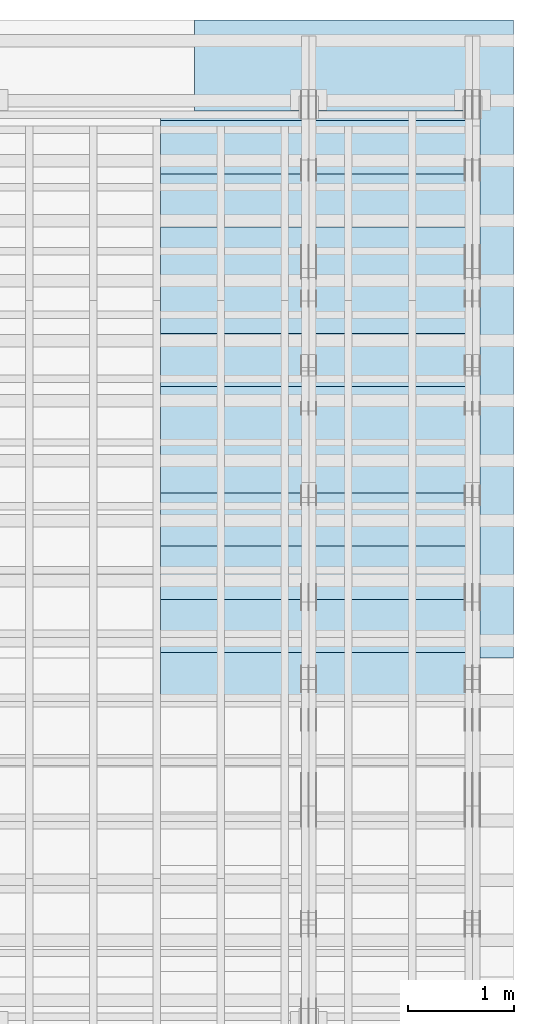
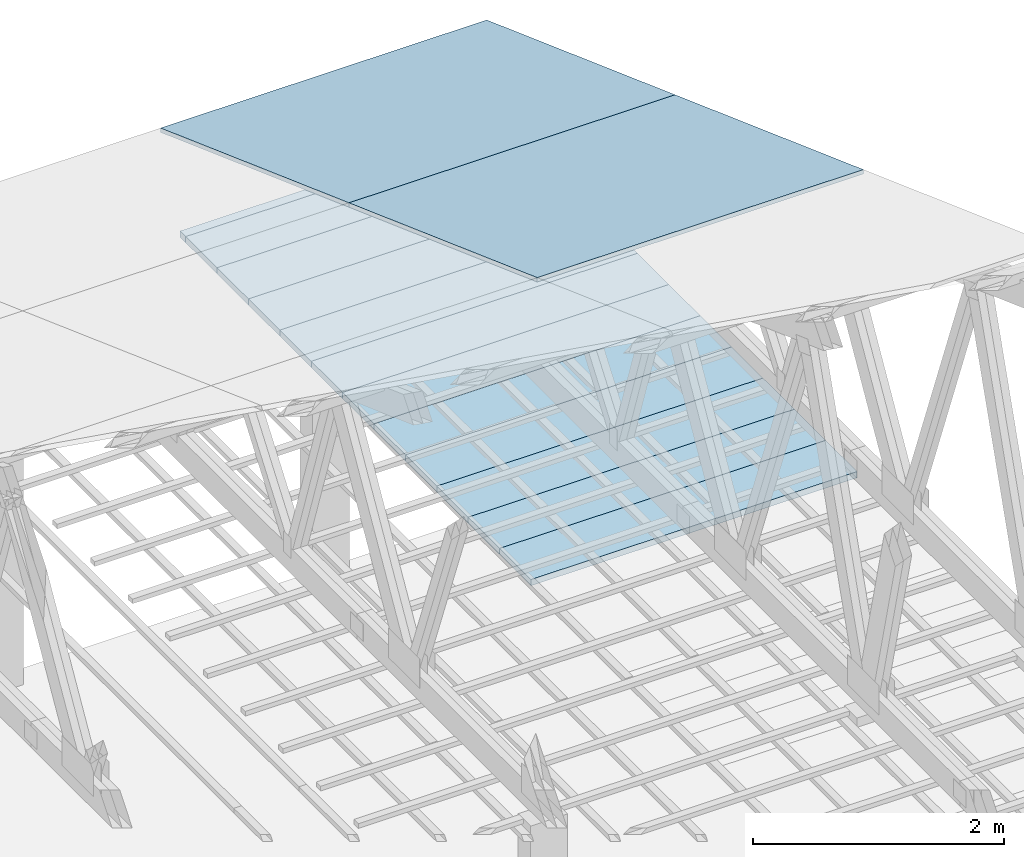
# One storey, part 11 of 189: 14 slabs, 14 elements without a shape of their own.
"""IFC2X3 building model written with IfcOpenShell, lengths in millimetres."""

from ifc_helpers import new_model, entity, si_unit, converted_unit, derived_unit, direction, frame, frame_2d, origin, origin_2d_with_axis, place, context, subcontext, project, spatial, rectangle, extrude, material, layer, layer_set, element, aggregate, save


model = new_model("IFC2X3")

# Units and contexts
model_context = context("Model", 3, precision=0.01, world=origin(), true_north=direction((6.12303176911189e-17, 1.0)))
body_context = subcontext(model_context, "Body", "Model", "MODEL_VIEW")
ifc_project = project(units=[si_unit("LENGTHUNIT", "METRE", prefix="MILLI"), si_unit("AREAUNIT", "SQUARE_METRE"), si_unit("VOLUMEUNIT", "CUBIC_METRE"), converted_unit("PLANEANGLEUNIT", "DEGREE", entity("IfcRatioMeasure", 0.0174532925199433), si_unit("PLANEANGLEUNIT", "RADIAN"), dimensions=[0, 0, 0, 0, 0, 0, 0]), si_unit("MASSUNIT", "GRAM", prefix="KILO"), derived_unit("MASSDENSITYUNIT", [(si_unit("MASSUNIT", "GRAM", prefix="KILO"), 1), (si_unit("LENGTHUNIT", "METRE"), -3)]), si_unit("TIMEUNIT", "SECOND"), si_unit("FREQUENCYUNIT", "HERTZ"), si_unit("THERMODYNAMICTEMPERATUREUNIT", "DEGREE_CELSIUS"), derived_unit("THERMALTRANSMITTANCEUNIT", [(si_unit("MASSUNIT", "GRAM", prefix="KILO"), 1), (si_unit("THERMODYNAMICTEMPERATUREUNIT", "KELVIN"), -1), (si_unit("TIMEUNIT", "SECOND"), -3)]), derived_unit("VOLUMETRICFLOWRATEUNIT", [(si_unit("LENGTHUNIT", "METRE"), 3), (si_unit("TIMEUNIT", "SECOND"), -1)]), si_unit("ELECTRICCURRENTUNIT", "AMPERE"), si_unit("ELECTRICVOLTAGEUNIT", "VOLT"), si_unit("POWERUNIT", "WATT"), si_unit("FORCEUNIT", "NEWTON"), si_unit("ILLUMINANCEUNIT", "LUX"), si_unit("LUMINOUSFLUXUNIT", "LUMEN"), si_unit("LUMINOUSINTENSITYUNIT", "CANDELA"), derived_unit("USERDEFINED", [(si_unit("MASSUNIT", "GRAM", prefix="KILO"), -1), (si_unit("LENGTHUNIT", "METRE"), -2), (si_unit("TIMEUNIT", "SECOND"), 3), (si_unit("LUMINOUSFLUXUNIT", "LUMEN"), 1)]), derived_unit("LINEARVELOCITYUNIT", [(si_unit("LENGTHUNIT", "METRE"), 1), (si_unit("TIMEUNIT", "SECOND"), -1)]), si_unit("PRESSUREUNIT", "PASCAL"), derived_unit("USERDEFINED", [(si_unit("LENGTHUNIT", "METRE"), -2), (si_unit("MASSUNIT", "GRAM", prefix="KILO"), 1), (si_unit("TIMEUNIT", "SECOND"), -2)])], contexts=[model_context])

# Site, building, storey
site_placement = place(None, origin())
site = spatial("IfcSite", under=ifc_project, at=site_placement, CompositionType="ELEMENT")
building_placement = place(site_placement, origin())
building = spatial("IfcBuilding", under=site, at=building_placement, CompositionType="ELEMENT")
storey_placement = place(building_placement, origin())
storey = spatial("IfcBuildingStorey", under=building, at=storey_placement, Name="Default", CompositionType="ELEMENT", Elevation=0.0)

# Roof, slab
roof_1_placement = place(storey_placement, frame((47153.4200853155, 27152.222636977, 238.115215731819)))
roof_1 = element("IfcRoof", 1, at=roof_1_placement, inside=storey, ShapeType="NOTDEFINED")
ifc_material_1 = material()
ifc_layer_1 = layer(ifc_material_1, 40.0)
ifc_layer_set_1 = layer_set([ifc_layer_1])
slab_1_placement = place(roof_1_placement, origin())
slab_1 = element("IfcSlab", 2, at=slab_1_placement, material=ifc_layer_set_1, PredefinedType="ROOF", context=body_context, shape_type="SweptSolid", body=[
    extrude(rectangle(XDim=3192.53331742773, YDim=2999.99999999999, at=frame_2d((0.0, 1.13686837721616e-13), x_axis=(0.0, 1.0))), frame((1500.0, 1500.0, 545.955351399304), z_axis=(0.0, 0.342020143325669, 0.939692620785908), x_axis=(1.0, 0.0, 0.0)), (0.0, -0.342020143325669, 0.939692620785908), 42.5671108990364),
])
aggregate(roof_1, [slab_1])

roof_2_placement = place(storey_placement, frame((47153.4200853155, 24152.222636977, 1330.02591853042)))
roof_2 = element("IfcRoof", 3, at=roof_2_placement, inside=storey, ShapeType="NOTDEFINED")
slab_2_placement = place(roof_2_placement, origin())
slab_2 = element("IfcSlab", 4, at=slab_2_placement, material=ifc_layer_set_1, PredefinedType="ROOF", context=body_context, shape_type="SweptSolid", body=[
    extrude(rectangle(XDim=3192.53331742773, YDim=2999.99999999999, at=frame_2d((0.0, 0.0), x_axis=(0.0, 1.0))), frame((1500.0, 1500.0, 545.955351399304), z_axis=(0.0, 0.342020143325669, 0.939692620785908), x_axis=(1.0, 0.0, 0.0)), (0.0, -0.342020143325669, 0.939692620785908), 42.5671108990358),
])
aggregate(roof_2, [slab_2])

roof_3_placement = place(storey_placement, frame((46837.7477027695, 23705.0, -150.0)))
roof_3 = element("IfcRoof", 5, at=roof_3_placement, inside=storey, ShapeType="NOTDEFINED")
ifc_material_2 = material(Name="NLRS_n7_isolatie MegaPlus_Kingspan")
ifc_layer_2 = layer(ifc_material_2, 60.0)
ifc_layer_set_2 = layer_set([ifc_layer_2])
slab_3_placement = place(roof_3_placement, origin())
slab_3 = element("IfcSlab", 6, at=slab_3_placement, material=ifc_layer_set_2, PredefinedType="ROOF", context=body_context, shape_type="SweptSolid", body=[
    extrude(rectangle(XDim=3000.00000000001, YDim=499.99999999999, at=origin_2d_with_axis()), frame((1500.0, 250.0, 0.0)), (0.0, 0.0, 1.0), 60.0),
])
aggregate(roof_3, [slab_3])

roof_4_placement = place(storey_placement, frame((46837.7477027695, 24205.0, -150.0)))
roof_4 = element("IfcRoof", 7, at=roof_4_placement, inside=storey, ShapeType="NOTDEFINED")
slab_4_placement = place(roof_4_placement, origin())
slab_4 = element("IfcSlab", 8, at=slab_4_placement, material=ifc_layer_set_2, PredefinedType="ROOF", context=body_context, shape_type="SweptSolid", body=[
    extrude(rectangle(XDim=3000.00000000001, YDim=499.99999999999, at=origin_2d_with_axis()), frame((1500.0, 250.0, 0.0)), (0.0, 0.0, 1.0), 60.0),
])
aggregate(roof_4, [slab_4])

roof_5_placement = place(storey_placement, frame((46837.7477027695, 24705.0, -150.0)))
roof_5 = element("IfcRoof", 9, at=roof_5_placement, inside=storey, ShapeType="NOTDEFINED")
slab_5_placement = place(roof_5_placement, origin())
slab_5 = element("IfcSlab", 10, at=slab_5_placement, material=ifc_layer_set_2, PredefinedType="ROOF", context=body_context, shape_type="SweptSolid", body=[
    extrude(rectangle(XDim=3000.00000000001, YDim=499.99999999999, at=origin_2d_with_axis()), frame((1500.0, 250.0, 0.0)), (0.0, 0.0, 1.0), 60.0),
])
aggregate(roof_5, [slab_5])

roof_6_placement = place(storey_placement, frame((46837.7477027695, 25205.0, -150.0)))
roof_6 = element("IfcRoof", 11, at=roof_6_placement, inside=storey, ShapeType="NOTDEFINED")
slab_6_placement = place(roof_6_placement, origin())
slab_6 = element("IfcSlab", 12, at=slab_6_placement, material=ifc_layer_set_2, PredefinedType="ROOF", context=body_context, shape_type="SweptSolid", body=[
    extrude(rectangle(XDim=3000.00000000001, YDim=499.99999999999, at=origin_2d_with_axis()), frame((1500.0, 250.0, 0.0)), (0.0, 0.0, 1.0), 60.0),
])
aggregate(roof_6, [slab_6])

roof_7_placement = place(storey_placement, frame((46837.7477027695, 25705.0, -150.0)))
roof_7 = element("IfcRoof", 13, at=roof_7_placement, inside=storey, ShapeType="NOTDEFINED")
slab_7_placement = place(roof_7_placement, origin())
slab_7 = element("IfcSlab", 14, at=slab_7_placement, material=ifc_layer_set_2, PredefinedType="ROOF", context=body_context, shape_type="SweptSolid", body=[
    extrude(rectangle(XDim=3000.00000000001, YDim=499.99999999999, at=origin_2d_with_axis()), frame((1500.0, 250.0, 0.0)), (0.0, 0.0, 1.0), 60.0),
])
aggregate(roof_7, [slab_7])

roof_8_placement = place(storey_placement, frame((46837.7477027695, 26205.0, -150.0)))
roof_8 = element("IfcRoof", 15, at=roof_8_placement, inside=storey, ShapeType="NOTDEFINED")
slab_8_placement = place(roof_8_placement, origin())
slab_8 = element("IfcSlab", 16, at=slab_8_placement, material=ifc_layer_set_2, PredefinedType="ROOF", context=body_context, shape_type="SweptSolid", body=[
    extrude(rectangle(XDim=3000.00000000001, YDim=499.99999999999, at=origin_2d_with_axis()), frame((1500.0, 250.0, 0.0)), (0.0, 0.0, 1.0), 60.0),
])
aggregate(roof_8, [slab_8])

roof_9_placement = place(storey_placement, frame((46837.7477027695, 26705.0, -150.0)))
roof_9 = element("IfcRoof", 17, at=roof_9_placement, inside=storey, ShapeType="NOTDEFINED")
slab_9_placement = place(roof_9_placement, origin())
slab_9 = element("IfcSlab", 18, at=slab_9_placement, material=ifc_layer_set_2, PredefinedType="ROOF", context=body_context, shape_type="SweptSolid", body=[
    extrude(rectangle(XDim=3000.00000000001, YDim=499.99999999999, at=origin_2d_with_axis()), frame((1500.0, 250.0, 0.0)), (0.0, 0.0, 1.0), 60.0),
])
aggregate(roof_9, [slab_9])

roof_10_placement = place(storey_placement, frame((46837.7477027695, 27205.0, -150.0)))
roof_10 = element("IfcRoof", 19, at=roof_10_placement, inside=storey, ShapeType="NOTDEFINED")
slab_10_placement = place(roof_10_placement, origin())
slab_10 = element("IfcSlab", 20, at=slab_10_placement, material=ifc_layer_set_2, PredefinedType="ROOF", context=body_context, shape_type="SweptSolid", body=[
    extrude(rectangle(XDim=3000.00000000001, YDim=499.99999999999, at=origin_2d_with_axis()), frame((1500.0, 250.0, 0.0)), (0.0, 0.0, 1.0), 60.0),
])
aggregate(roof_10, [slab_10])

roof_11_placement = place(storey_placement, frame((46837.7477027695, 27705.0, -150.0)))
roof_11 = element("IfcRoof", 21, at=roof_11_placement, inside=storey, ShapeType="NOTDEFINED")
slab_11_placement = place(roof_11_placement, origin())
slab_11 = element("IfcSlab", 22, at=slab_11_placement, material=ifc_layer_set_2, PredefinedType="ROOF", context=body_context, shape_type="SweptSolid", body=[
    extrude(rectangle(XDim=3000.00000000001, YDim=499.99999999999, at=origin_2d_with_axis()), frame((1500.0, 250.0, 0.0)), (0.0, 0.0, 1.0), 60.0),
])
aggregate(roof_11, [slab_11])

roof_12_placement = place(storey_placement, frame((46837.7477027695, 28205.0, -150.0)))
roof_12 = element("IfcRoof", 23, at=roof_12_placement, inside=storey, ShapeType="NOTDEFINED")
slab_12_placement = place(roof_12_placement, origin())
slab_12 = element("IfcSlab", 24, at=slab_12_placement, material=ifc_layer_set_2, PredefinedType="ROOF", context=body_context, shape_type="SweptSolid", body=[
    extrude(rectangle(XDim=3000.00000000001, YDim=499.99999999999, at=origin_2d_with_axis()), frame((1500.0, 250.0, 0.0)), (0.0, 0.0, 1.0), 60.0),
])
aggregate(roof_12, [slab_12])

roof_13_placement = place(storey_placement, frame((46837.7477027695, 28795.0, -150.0)))
roof_13 = element("IfcRoof", 25, at=roof_13_placement, inside=storey, ShapeType="NOTDEFINED")
slab_13_placement = place(roof_13_placement, origin())
slab_13 = element("IfcSlab", 26, at=slab_13_placement, material=ifc_layer_set_2, PredefinedType="ROOF", context=body_context, shape_type="SweptSolid", body=[
    extrude(rectangle(XDim=3000.00000000001, YDim=499.99999999999, at=origin_2d_with_axis()), frame((1500.0, 250.0, 0.0)), (0.0, 0.0, 1.0), 60.0),
])
aggregate(roof_13, [slab_13])

roof_14_placement = place(storey_placement, frame((46837.7477027695, 28705.0, -150.0)))
roof_14 = element("IfcRoof", 27, at=roof_14_placement, inside=storey, ShapeType="NOTDEFINED")
slab_14_placement = place(roof_14_placement, origin())
slab_14 = element("IfcSlab", 28, at=slab_14_placement, material=ifc_layer_set_2, PredefinedType="ROOF", context=body_context, shape_type="SweptSolid", body=[
    extrude(rectangle(XDim=3000.00000000001, YDim=499.99999999999, at=origin_2d_with_axis()), frame((1500.0, 250.0, 0.0)), (0.0, 0.0, 1.0), 60.0),
])
aggregate(roof_14, [slab_14])

save(model, "model.ifc")
